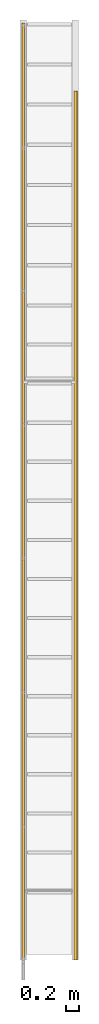
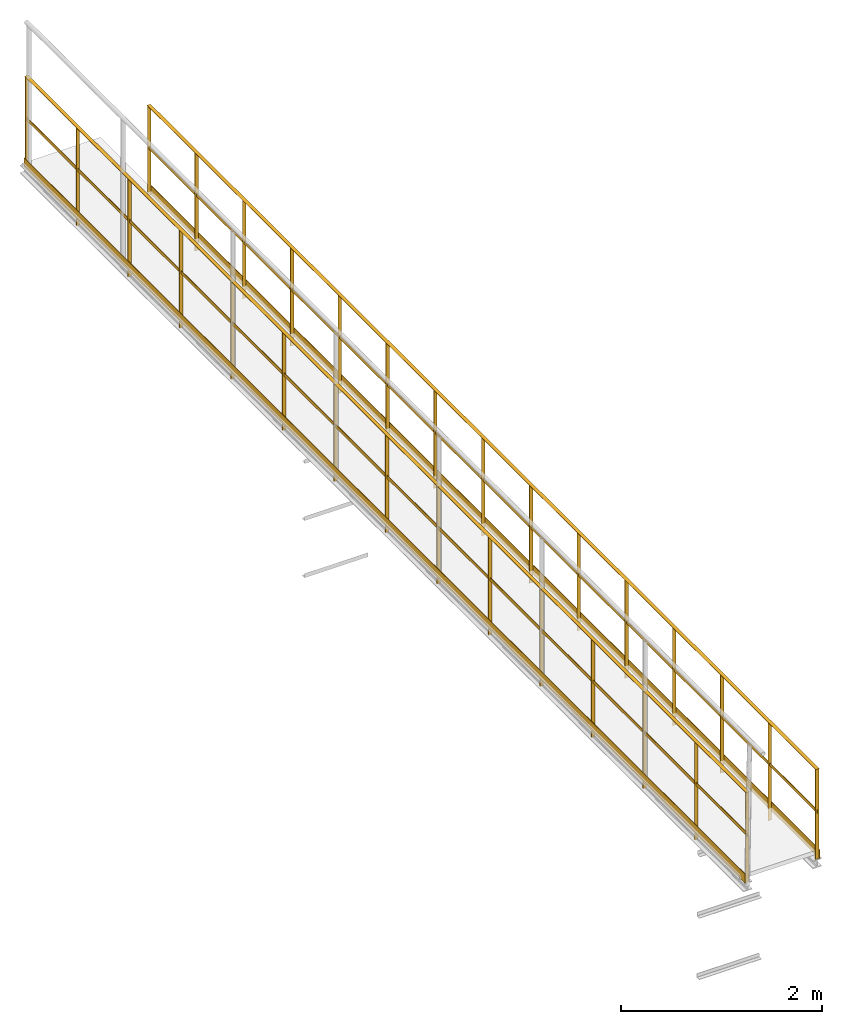
# One storey, part 6 of 6: 2 railings.
"""IFC2X3 building model written with IfcOpenShell, lengths in metres."""

import ifcopenshell
import ifcopenshell.guid

model = None  # the IFC model being written
_history = None  # IfcOwnerHistory: only IFC2X3 demands one
_inside = {}  # id of a spatial element -> (the spatial element, [elements in it])
_under = {}  # id of a project, library or spatial element -> (it, [spatial elements below it])
_declared = {}  # id of a project -> (the project, [libraries it declares])
_typed = {}  # id of a type object -> (the type object, [elements of that type])
_made_of = {}  # id of a material, layer set ... -> (it, [elements and type objects made of it])


def new_model(schema):
    """Start an empty IFC model of exactly this schema.

    Asked for "IFC4X3", IfcOpenShell would pick the latest addendum, in which some entities
    have other attributes; the version numbers below select the first issue.
    IFC2X3 requires an IfcOwnerHistory on every rooted entity: one is made here for all.
    """
    global model, _history
    if schema == "IFC4X3":
        model = ifcopenshell.file(schema_version=(4, 3, 0, 0))
    else:
        model = ifcopenshell.file(schema=schema)
    _inside.clear()
    _under.clear()
    _declared.clear()
    _typed.clear()
    _made_of.clear()
    _history = None
    if model.schema == "IFC2X3":
        org = make("IfcOrganization", Name="unknown")
        user = make(
            "IfcPersonAndOrganization",
            ThePerson=make("IfcPerson", FamilyName="unknown"),
            TheOrganization=org,
        )
        app = make(
            "IfcApplication",
            ApplicationDeveloper=org,
            Version="unknown",
            ApplicationFullName="unknown",
            ApplicationIdentifier="unknown",
        )
        _history = make(
            "IfcOwnerHistory",
            OwningUser=user,
            OwningApplication=app,
            ChangeAction="ADDED",
            CreationDate=0,
        )
    return model


def make(cls, **values):
    """One entity of the class cls with the attributes given. An attribute that is None is left unset."""
    return model.create_entity(
        cls, **{name: value for name, value in values.items() if value is not None}
    )


def entity(cls, *values):
    """Any entity or typed value of the class cls, its attributes in the order of the schema. None: left unset."""
    e = model.create_entity(cls)
    for i, value in enumerate(values):
        if value is not None:
            e[i] = value
    return e


def rooted(cls, **values):
    """An entity with a GlobalId (a new one), such as an element, a storey or a relation."""
    return make(cls, GlobalId=ifcopenshell.guid.new(), OwnerHistory=_history, **values)


def si_unit(unit_type, name, prefix=None):
    """IfcSIUnit, for example si_unit("LENGTHUNIT", "METRE", prefix="MILLI")."""
    return make("IfcSIUnit", UnitType=unit_type, Prefix=prefix, Name=name)


def converted_unit(unit_type, name, factor, base, dimensions=None, offset=None):
    """IfcConversionBasedUnit, such as the inch: factor (a typed value) times the base unit."""
    return make(
        "IfcConversionBasedUnit"
        if offset is None
        else "IfcConversionBasedUnitWithOffset",
        ConversionOffset=offset,
        Dimensions=None
        if dimensions is None
        else entity("IfcDimensionalExponents", *dimensions),
        UnitType=unit_type,
        Name=name,
        ConversionFactor=make(
            "IfcMeasureWithUnit", ValueComponent=factor, UnitComponent=base
        ),
    )


def derived_unit(unit_type, elements):
    """IfcDerivedUnit: a product of units, each with its exponent."""
    return make(
        "IfcDerivedUnit",
        Elements=[
            make("IfcDerivedUnitElement", Unit=unit, Exponent=power)
            for unit, power in elements
        ],
        UnitType=unit_type,
    )


def assignment(units):
    """IfcUnitAssignment: the units of a project."""
    return None if units is None else make("IfcUnitAssignment", Units=units)


def point(xyz):
    """IfcCartesianPoint."""
    return None if xyz is None else make("IfcCartesianPoint", Coordinates=xyz)


def direction(xyz):
    """IfcDirection."""
    return None if xyz is None else make("IfcDirection", DirectionRatios=xyz)


def frame(location, z_axis=None, x_axis=None):
    """IfcAxis2Placement3D, a coordinate frame: its origin and axes. An axis left out is left unset."""
    return make(
        "IfcAxis2Placement3D",
        Location=point(location),
        Axis=direction(z_axis),
        RefDirection=direction(x_axis),
    )


def frame_2d(location, x_axis=None):
    """IfcAxis2Placement2D, a coordinate frame in the plane: its origin and x axis."""
    return make(
        "IfcAxis2Placement2D", Location=point(location), RefDirection=direction(x_axis)
    )


def origin():
    """The frame at (0, 0, 0) with its axes left unset."""
    return frame((0.0, 0.0, 0.0))


def origin_2d_with_axis():
    """The frame at (0, 0) in the plane with the x axis (1, 0) written out."""
    return frame_2d((0.0, 0.0), x_axis=(1.0, 0.0))


def place(relative_to, where):
    """IfcLocalPlacement: puts the frame where relative to a parent placement (None: the world)."""
    return make(
        "IfcLocalPlacement", PlacementRelTo=relative_to, RelativePlacement=where
    )


def context(
    kind, dimensions, precision=None, world=None, true_north=None, identifier=None
):
    """IfcGeometricRepresentationContext, for example the 3D "Model" context."""
    return make(
        "IfcGeometricRepresentationContext",
        ContextIdentifier=identifier,
        ContextType=kind,
        CoordinateSpaceDimension=dimensions,
        Precision=precision,
        WorldCoordinateSystem=world,
        TrueNorth=true_north,
    )


def subcontext(parent, identifier, kind, view, scale=None):
    """IfcGeometricRepresentationSubContext, for example "Body" below "Model"."""
    return make(
        "IfcGeometricRepresentationSubContext",
        ContextIdentifier=identifier,
        ContextType=kind,
        ParentContext=parent,
        TargetScale=scale,
        TargetView=view,
    )


def project(units=None, contexts=None):
    """IfcProject with its units and contexts."""
    return rooted(
        "IfcProject",
        Name="project",
        RepresentationContexts=contexts,
        UnitsInContext=assignment(units),
    )


def spatial(cls, under=None, at=None, **own):
    """A site, building, storey or space (cls), placed at a placement, below another one or the project."""
    s = rooted(cls, ObjectPlacement=at, **own)
    if under is not None:
        _under.setdefault(under.id(), (under, []))[1].append(s)
    return s


def profile(cls, at=None, kind="AREA", **sizes):
    """A parametric profile (cls). Its sizes go by their IFC names, for example OverallWidth=200.0."""
    return make(cls, ProfileType=kind, Position=at, **sizes)


def rectangle(**sizes):
    """IfcRectangleProfileDef."""
    return profile("IfcRectangleProfileDef", **sizes)


def extrude(swept, where, along, depth):
    """IfcExtrudedAreaSolid: the profile swept, set in the frame where, extruded along a direction by depth."""
    return make(
        "IfcExtrudedAreaSolid",
        SweptArea=swept,
        Position=where,
        ExtrudedDirection=direction(along),
        Depth=depth,
    )


def shape(context_of_items, identifier, shape_type, items):
    """IfcShapeRepresentation: the items that make up one representation, for example the "Body"."""
    return make(
        "IfcShapeRepresentation",
        ContextOfItems=context_of_items,
        RepresentationIdentifier=identifier,
        RepresentationType=shape_type,
        Items=items,
    )


def material(Name=None, Category=None):
    """IfcMaterial."""
    return make("IfcMaterial", Name=Name, Category=Category)


def material_list(materials):
    """IfcMaterialList."""
    return make("IfcMaterialList", Materials=materials)


def made_of(thing, what):
    """Note that an element or type object is made of a material, layer set ...; save() writes the relation."""
    if what is not None:
        _made_of.setdefault(what.id(), (what, []))[1].append(thing)
    return thing


def type_object(cls, material=None, **own):
    """A type object (cls), such as IfcWallType, which elements share."""
    return made_of(rooted(cls, **own), material)


def element(
    cls,
    number,
    at=None,
    inside=None,
    cuts=None,
    type_object=None,
    material=None,
    context=None,
    identifier="Body",
    shape_type=None,
    held_by="IfcProductDefinitionShape",
    body=None,
    shapes=None,
    **own,
):
    """One element of the class cls, such as IfcWall. Its Tag is "e" and its number.

    at: its placement. inside: the storey or other place that contains it. cuts: it is an
    opening in that element (IfcRelVoidsElement). A single representation is given by context,
    identifier, shape_type and body (its items); several are given by shapes. held_by: the class
    of the entity that holds the representations. save() writes the other relations.
    """
    e = rooted(cls, Tag="e%d" % number, ObjectPlacement=at, **own)
    if body is not None:
        shapes = [shape(context, identifier, shape_type, body)]
    if shapes is not None:
        e.Representation = make(held_by, Representations=shapes)
    if inside is not None:
        _inside.setdefault(inside.id(), (inside, []))[1].append(e)
    if cuts is not None:
        rooted(
            "IfcRelVoidsElement", RelatingBuildingElement=cuts, RelatedOpeningElement=e
        )
    if type_object is not None:
        _typed.setdefault(type_object.id(), (type_object, []))[1].append(e)
    return made_of(e, material)


def aggregate(whole, parts):
    """IfcRelAggregates: a whole, such as a stair, and the parts it consists of."""
    return rooted("IfcRelAggregates", RelatingObject=whole, RelatedObjects=parts)


def save(model, path):
    """Write the relations noted so far, then the file.

    IfcRelAggregates (storeys below a building ...), IfcRelContainedInSpatialStructure (elements
    in a storey), IfcRelDefinesByType, IfcRelAssociatesMaterial and IfcRelDeclares: one each for
    every whole, place, type object, material and project.
    """
    for whole, parts in _under.values():
        aggregate(whole, parts)
    for where, things in _inside.values():
        rooted(
            "IfcRelContainedInSpatialStructure",
            RelatedElements=things,
            RelatingStructure=where,
        )
    for kind, things in _typed.values():
        rooted("IfcRelDefinesByType", RelatedObjects=things, RelatingType=kind)
    for what, things in _made_of.values():
        rooted("IfcRelAssociatesMaterial", RelatedObjects=things, RelatingMaterial=what)
    for by, libraries in _declared.values():
        rooted("IfcRelDeclares", RelatingContext=by, RelatedDefinitions=libraries)
    model.write(path)


model = new_model("IFC2X3")

# Units and contexts
model_context = context("Model", 3, precision=1e-05, world=origin(), true_north=direction((6.123233995736766e-17, 1.0)))
body_context = subcontext(model_context, "Body", "Model", "MODEL_VIEW")
ifc_project = project(units=[si_unit("LENGTHUNIT", "METRE"), converted_unit("PLANEANGLEUNIT", "DEGREE", entity("IfcPlaneAngleMeasure", 0.017453292519943278), si_unit("PLANEANGLEUNIT", "RADIAN"), dimensions=[0, 0, 0, 0, 0, 0, 0]), si_unit("AREAUNIT", "SQUARE_METRE"), derived_unit("THERMALTRANSMITTANCEUNIT", [(si_unit("MASSUNIT", "GRAM", prefix="KILO"), 1), (si_unit("THERMODYNAMICTEMPERATUREUNIT", "KELVIN"), -1), (si_unit("TIMEUNIT", "SECOND"), -3)])], contexts=[model_context])

# Site, building, storey
site_placement = place(None, origin())
site = spatial("IfcSite", under=ifc_project, at=site_placement, CompositionType="ELEMENT")
building_placement = place(site_placement, origin())
building = spatial("IfcBuilding", under=site, at=building_placement, CompositionType="ELEMENT")
storey_placement = place(building_placement, frame((0.0, 0.0, 8.8)))
storey = spatial("IfcBuildingStorey", under=building, at=storey_placement, Name="Piso 2.3", CompositionType="ELEMENT", Elevation=8.8)

# Railings
ifc_material_1 = material(Name="Metal - Stainless Steel,Polished")
ifc_material_2 = material()
ifc_material_list = material_list([ifc_material_1, ifc_material_2])
railing_type = type_object("IfcRailingType", Name="Railing:1100mm", PredefinedType="NOTDEFINED")
railing_1_placement = place(storey_placement, origin())
element("IfcRailing", 1, at=railing_1_placement, inside=storey, type_object=railing_type, material=ifc_material_list, Name="Railing:1100mm", ObjectType="Railing:1100mm", PredefinedType="NOTDEFINED", context=body_context, shape_type="SweptSolid", body=[
    extrude(rectangle(XDim=0.04000000000000011, YDim=0.0049999999999999455, at=frame_2d((-2.706168622523819e-16, 5.414505649392609e-16), x_axis=(1.0, 0.0))), frame((3.704197135192138, 8.992555363397157, -0.050000000000000544)), (0.0, 0.0, 1.0), 1.195),
    extrude(rectangle(XDim=0.04000000000000011, YDim=0.0049999999999999455, at=frame_2d((-2.706168622523819e-16, 5.414505649392609e-16), x_axis=(1.0, 0.0))), frame((3.704197135192138, 7.964940633428197, -0.050000000000000544)), (0.0, 0.0, 1.0), 1.195),
    extrude(rectangle(XDim=0.04000000000000011, YDim=0.0049999999999999455, at=frame_2d((-2.706168622523819e-16, 5.414505649392609e-16), x_axis=(1.0, 0.0))), frame((3.704197135192138, 6.937325903459234, -0.050000000000000544)), (0.0, 0.0, 1.0), 1.195),
    extrude(rectangle(XDim=0.04000000000000011, YDim=0.0049999999999999455, at=frame_2d((-2.706168622523819e-16, -5.414505649392609e-16), x_axis=(1.0, 0.0))), frame((3.704197135192138, 5.909711173490274, -0.050000000000000544)), (0.0, 0.0, 1.0), 1.195),
    extrude(rectangle(XDim=0.04000000000000011, YDim=0.0049999999999999455, at=frame_2d((-2.706168622523819e-16, 5.414505649392609e-16), x_axis=(1.0, 0.0))), frame((3.704197135192138, 4.882096443521311, -0.050000000000000544)), (0.0, 0.0, 1.0), 1.195),
    extrude(rectangle(XDim=0.04000000000000011, YDim=0.004999999999999946, at=frame_2d((-2.706168622523819e-16, 0.0), x_axis=(1.0, 0.0))), frame((3.704197135192138, 3.854481713552348, -0.050000000000000544)), (0.0, 0.0, 1.0), 1.195),
    extrude(rectangle(XDim=0.04000000000000011, YDim=0.004999999999999946, at=frame_2d((-2.706168622523819e-16, 0.0), x_axis=(1.0, 0.0))), frame((3.704197135192138, 2.8268669835833866, -0.050000000000000544)), (0.0, 0.0, 1.0), 1.195),
    extrude(rectangle(XDim=0.04000000000000011, YDim=0.004999999999999946, at=frame_2d((-2.706168622523819e-16, 0.0), x_axis=(1.0, 0.0))), frame((3.704197135192138, 1.799252253614424, -0.050000000000000544)), (0.0, 0.0, 1.0), 1.195),
    extrude(rectangle(XDim=0.04000000000000011, YDim=0.005000000000000082, at=frame_2d((-2.706168622523819e-16, -6.765421556309548e-17), x_axis=(1.0, 0.0))), frame((3.704197135192138, 0.7716375236454627, -0.050000000000000544)), (0.0, 0.0, 1.0), 1.195),
    extrude(rectangle(XDim=0.04000000000000011, YDim=0.005000000000000014, at=frame_2d((-2.706168622523819e-16, 0.0), x_axis=(1.0, 0.0))), frame((3.704197135192138, -0.2559772063235009, -0.050000000000000544)), (0.0, 0.0, 1.0), 1.195),
    extrude(rectangle(XDim=0.04000000000000011, YDim=0.004999999999999946, at=frame_2d((-2.706168622523819e-16, 0.0), x_axis=(1.0, 0.0))), frame((3.704197135192138, -1.2835919362924624, -0.050000000000000544)), (0.0, 0.0, 1.0), 1.195),
    extrude(rectangle(XDim=0.04000000000000011, YDim=0.004999999999999946, at=frame_2d((-2.706168622523819e-16, 0.0), x_axis=(1.0, 0.0))), frame((3.704197135192138, -2.3112066662614237, -0.050000000000000544)), (0.0, 0.0, 1.0), 1.195),
    extrude(rectangle(XDim=0.04000000000000011, YDim=0.004999999999999946, at=frame_2d((-2.706168622523819e-16, 0.0), x_axis=(1.0, 0.0))), frame((3.704197135192138, -3.338821396230387, -0.050000000000000544)), (0.0, 0.0, 1.0), 1.195),
    extrude(rectangle(XDim=0.04000000000000011, YDim=0.004999999999998863, at=frame_2d((-2.706168622523819e-16, 1.0829011298785218e-15), x_axis=(1.0, 0.0))), frame((3.704197135192138, 10.01017009336612, 0.04999999999999946)), (0.0, 0.0, 1.0), 1.0950000000000002),
    extrude(rectangle(XDim=0.04000000000000011, YDim=0.004999999999999946, at=frame_2d((-2.706168622523819e-16, 0.0), x_axis=(1.0, 0.0))), frame((3.704197135192138, -4.356436126199348, 0.04999999999999946)), (0.0, 0.0, 1.0), 1.0950000000000002),
    extrude(rectangle(XDim=14.386606219565468, YDim=0.004999999999999946, at=frame_2d((8.881784197001252e-16, 0.0), x_axis=(1.0, 0.0))), frame((3.6791971351921418, 2.826866983583379, 0.04999999999999946), z_axis=(0.0, 0.0, 1.0), x_axis=(0.0, 1.0, 0.0)), (0.0, 0.0, 1.0), 0.1099999999999999),
    extrude(rectangle(XDim=14.386606219565468, YDim=0.0049999999999999455, at=frame_2d((8.881784197001252e-16, 5.414505649392609e-16), x_axis=(1.0, 0.0))), frame((3.7041971351921426, 2.826866983583379, 0.61), z_axis=(0.0, 0.0, 1.0), x_axis=(0.0, 1.0, 0.0)), (0.0, 0.0, 1.0), 0.03999999999999957),
    extrude(rectangle(XDim=14.386606219565468, YDim=0.04000000000000011, at=frame_2d((8.881784197001252e-16, 2.706168622523819e-16), x_axis=(1.0, 0.0))), frame((3.7041971351921426, 2.826866983583379, 1.1449999999999974), z_axis=(0.0, 0.0, 1.0), x_axis=(0.0, 1.0, 0.0)), (0.0, 0.0, 1.0), 0.005000000000001029),
])
railing_2_placement = place(storey_placement, origin())
element("IfcRailing", 2, at=railing_2_placement, inside=storey, type_object=railing_type, material=ifc_material_list, Name="Railing:1100mm", ObjectType="Railing:1100mm", PredefinedType="NOTDEFINED", context=body_context, shape_type="SweptSolid", body=[
    extrude(rectangle(XDim=0.0049999999999999455, YDim=0.04000000000000011, at=frame_2d((-5.414505649392609e-16, -2.706168622523819e-16), x_axis=(1.0, 0.0))), frame((4.509197135192179, 8.020706730943509, -0.050000000000000544), z_axis=(0.0, 0.0, 1.0), x_axis=(0.0, 1.0, 0.0)), (0.0, 0.0, 1.0), 1.195),
    extrude(rectangle(XDim=0.0049999999999999455, YDim=0.04000000000000011, at=frame_2d((-5.414505649392609e-16, -2.706168622523819e-16), x_axis=(1.0, 0.0))), frame((4.509197135192179, 7.067849588086367, -0.050000000000000544), z_axis=(0.0, 0.0, 1.0), x_axis=(0.0, 1.0, 0.0)), (0.0, 0.0, 1.0), 1.195),
    extrude(rectangle(XDim=0.0049999999999999455, YDim=0.04000000000000011, at=frame_2d((-5.414505649392609e-16, -2.706168622523819e-16), x_axis=(1.0, 0.0))), frame((4.509197135192179, 6.114992445229224, -0.050000000000000544), z_axis=(0.0, 0.0, 1.0), x_axis=(0.0, 1.0, 0.0)), (0.0, 0.0, 1.0), 1.195),
    extrude(rectangle(XDim=0.0049999999999999455, YDim=0.04000000000000011, at=frame_2d((-5.414505649392609e-16, -2.706168622523819e-16), x_axis=(1.0, 0.0))), frame((4.509197135192179, 5.162135302372081, -0.050000000000000544), z_axis=(0.0, 0.0, 1.0), x_axis=(0.0, 1.0, 0.0)), (0.0, 0.0, 1.0), 1.195),
    extrude(rectangle(XDim=0.004999999999999946, YDim=0.04000000000000011, at=frame_2d((0.0, -2.706168622523819e-16), x_axis=(1.0, 0.0))), frame((4.509197135192179, 4.2092781595149384, -0.050000000000000544), z_axis=(0.0, 0.0, 1.0), x_axis=(0.0, 1.0, 0.0)), (0.0, 0.0, 1.0), 1.195),
    extrude(rectangle(XDim=0.0049999999999999455, YDim=0.04000000000000011, at=frame_2d((-5.414505649392609e-16, 2.706168622523819e-16), x_axis=(1.0, 0.0))), frame((4.509197135192179, 3.2564210166577956, -0.050000000000000544), z_axis=(0.0, 0.0, 1.0), x_axis=(0.0, 1.0, 0.0)), (0.0, 0.0, 1.0), 1.195),
    extrude(rectangle(XDim=0.004999999999999946, YDim=0.04000000000000011, at=frame_2d((0.0, 2.706168622523819e-16), x_axis=(1.0, 0.0))), frame((4.509197135192179, 2.303563873800652, -0.050000000000000544), z_axis=(0.0, 0.0, 1.0), x_axis=(0.0, 1.0, 0.0)), (0.0, 0.0, 1.0), 1.195),
    extrude(rectangle(XDim=0.004999999999999946, YDim=0.04000000000000011, at=frame_2d((0.0, 2.706168622523819e-16), x_axis=(1.0, 0.0))), frame((4.509197135192179, 1.350706730943509, -0.050000000000000544), z_axis=(0.0, 0.0, 1.0), x_axis=(0.0, 1.0, 0.0)), (0.0, 0.0, 1.0), 1.195),
    extrude(rectangle(XDim=0.005000000000000014, YDim=0.04000000000000011, at=frame_2d((0.0, 2.706168622523819e-16), x_axis=(1.0, 0.0))), frame((4.509197135192179, 0.3978495880863662, -0.050000000000000544), z_axis=(0.0, 0.0, 1.0), x_axis=(0.0, 1.0, 0.0)), (0.0, 0.0, 1.0), 1.195),
    extrude(rectangle(XDim=0.005000000000000014, YDim=0.04000000000000011, at=frame_2d((0.0, 2.706168622523819e-16), x_axis=(1.0, 0.0))), frame((4.509197135192179, -0.5550075547707766, -0.050000000000000544), z_axis=(0.0, 0.0, 1.0), x_axis=(0.0, 1.0, 0.0)), (0.0, 0.0, 1.0), 1.195),
    extrude(rectangle(XDim=0.004999999999999946, YDim=0.04000000000000011, at=frame_2d((0.0, 2.706168622523819e-16), x_axis=(1.0, 0.0))), frame((4.509197135192179, -1.5078646976279195, -0.050000000000000544), z_axis=(0.0, 0.0, 1.0), x_axis=(0.0, 1.0, 0.0)), (0.0, 0.0, 1.0), 1.195),
    extrude(rectangle(XDim=0.004999999999999946, YDim=0.04000000000000011, at=frame_2d((0.0, 2.706168622523819e-16), x_axis=(1.0, 0.0))), frame((4.509197135192178, -2.460721840485062, -0.050000000000000544), z_axis=(0.0, 0.0, 1.0), x_axis=(0.0, 1.0, 0.0)), (0.0, 0.0, 1.0), 1.195),
    extrude(rectangle(XDim=0.0049999999999999455, YDim=0.04000000000000011, at=frame_2d((-5.414505649392609e-16, 2.706168622523819e-16), x_axis=(1.0, 0.0))), frame((4.509197135192178, -3.4135789833422043, -0.050000000000000544), z_axis=(0.0, 0.0, 1.0), x_axis=(0.0, 1.0, 0.0)), (0.0, 0.0, 1.0), 1.195),
    extrude(rectangle(XDim=0.0049999999999999455, YDim=0.04000000000000011, at=frame_2d((-5.414505649392609e-16, -2.706168622523819e-16), x_axis=(1.0, 0.0))), frame((4.50919713519218, 8.963563873800652, 0.04999999999999946), z_axis=(0.0, 0.0, 1.0), x_axis=(0.0, 1.0, 0.0)), (0.0, 0.0, 1.0), 1.0950000000000002),
    extrude(rectangle(XDim=0.0049999999999999455, YDim=0.04000000000000011, at=frame_2d((5.414505649392609e-16, 2.706168622523819e-16), x_axis=(1.0, 0.0))), frame((4.509197135192178, -4.356436126199348, 0.04999999999999946), z_axis=(0.0, 0.0, 1.0), x_axis=(0.0, 1.0, 0.0)), (0.0, 0.0, 1.0), 1.0950000000000002),
    extrude(rectangle(XDim=13.34, YDim=0.004999999999999946, at=frame_2d((0.0, -2.706168622523819e-16), x_axis=(1.0, 0.0))), frame((4.534197135192174, 2.303563873800645, 0.04999999999999946), z_axis=(0.0, 0.0, 1.0), x_axis=(0.0, 1.0, 0.0)), (0.0, 0.0, 1.0), 0.1099999999999999),
    extrude(rectangle(XDim=13.34, YDim=0.004999999999999946, at=frame_2d((0.0, -2.706168622523819e-16), x_axis=(1.0, 0.0))), frame((4.509197135192174, 2.303563873800645, 0.61), z_axis=(0.0, 0.0, 1.0), x_axis=(0.0, 1.0, 0.0)), (0.0, 0.0, 1.0), 0.03999999999999957),
    extrude(rectangle(XDim=13.34, YDim=0.04000000000000011, at=origin_2d_with_axis()), frame((4.509197135192175, 2.303563873800645, 1.1449999999999974), z_axis=(0.0, 0.0, 1.0), x_axis=(0.0, 1.0, 0.0)), (0.0, 0.0, 1.0), 0.005000000000001029),
])

save(model, "model.ifc")
